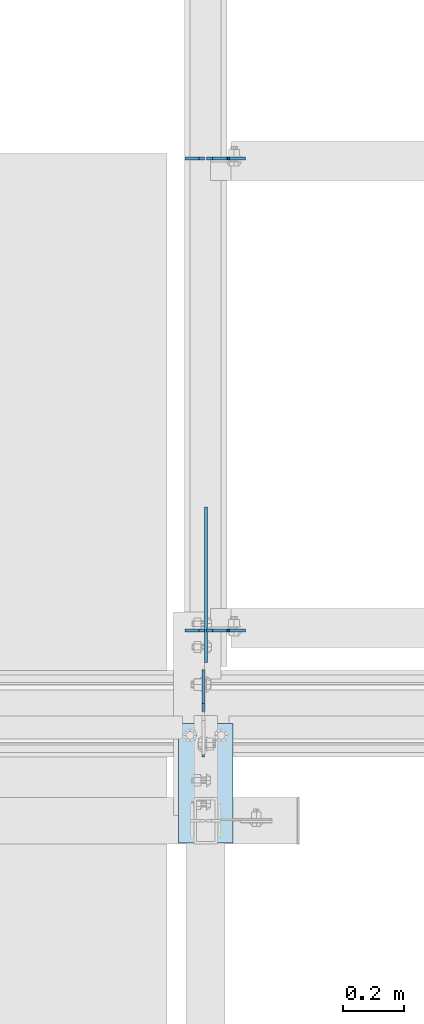
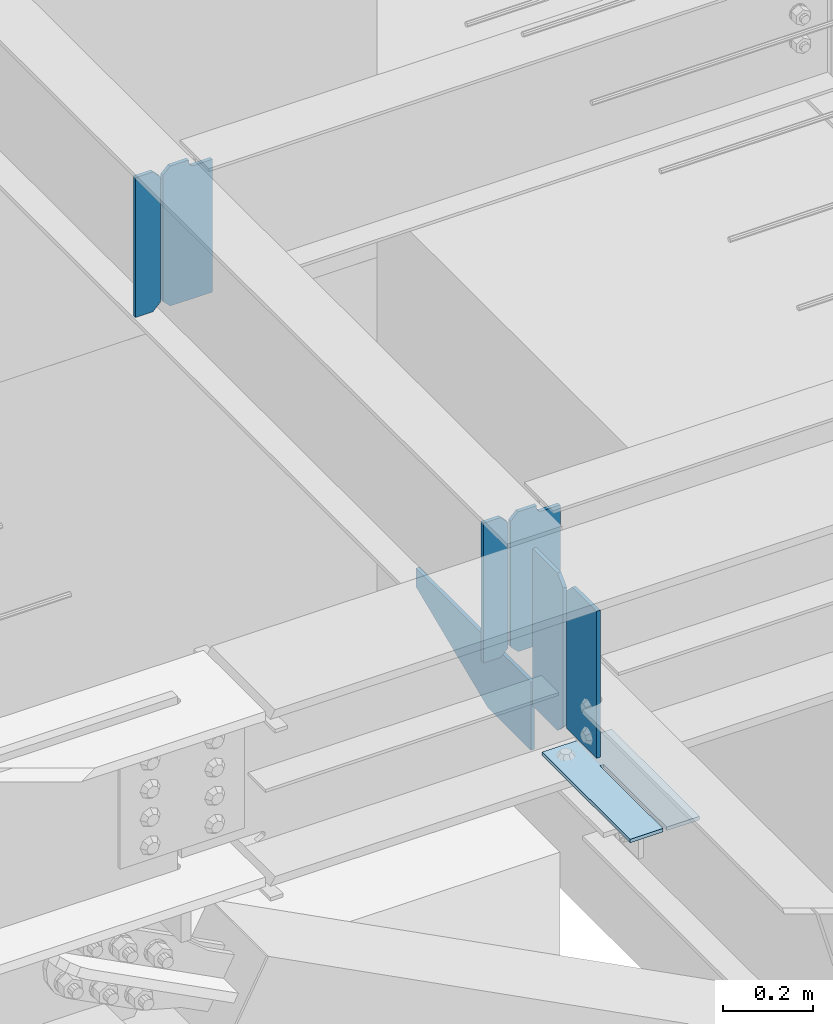
# One storey, part 999 of 1179: 8 plates, 3 elements without a shape of their own.
"""IFC2X3 building model written with IfcOpenShell, lengths in millimetres."""

from ifc_helpers import new_model, si_unit, frame, origin_with_axes, place, context, subcontext, project, spatial, faceted_brep, material, type_object, element, aggregate, save


model = new_model("IFC2X3")

# Units and contexts
model_context = context("Model", 3, precision=1e-05, world=origin_with_axes())
body_context = subcontext(model_context, "Body", "Model", "MODEL_VIEW")
ifc_project = project(units=[si_unit("LENGTHUNIT", "METRE", prefix="MILLI"), si_unit("AREAUNIT", "SQUARE_METRE"), si_unit("VOLUMEUNIT", "CUBIC_METRE"), si_unit("MASSUNIT", "GRAM", prefix="KILO"), si_unit("TIMEUNIT", "SECOND"), si_unit("PLANEANGLEUNIT", "RADIAN"), si_unit("SOLIDANGLEUNIT", "STERADIAN"), si_unit("THERMODYNAMICTEMPERATUREUNIT", "DEGREE_CELSIUS"), si_unit("LUMINOUSINTENSITYUNIT", "LUMEN")], contexts=[model_context])

# Site, building, storey
site_placement = place(None, origin_with_axes())
site = spatial("IfcSite", under=ifc_project, at=site_placement, CompositionType="ELEMENT")
building_placement = place(site_placement, origin_with_axes())
building = spatial("IfcBuilding", under=site, at=building_placement, Name="Undefined", CompositionType="ELEMENT")
storey_placement = place(building_placement, origin_with_axes())
storey = spatial("IfcBuildingStorey", under=building, at=storey_placement, Name="Undefined", CompositionType="ELEMENT", Elevation=0.0)

# Assembly, plates
assembly_1_placement = place(storey_placement, origin_with_axes())
assembly_1 = element("IfcElementAssembly", 1, at=assembly_1_placement, inside=storey, Name="BEAM", AssemblyPlace="NOTDEFINED", PredefinedType="RIGID_FRAME")
ifc_material = material(Name="STEEL/A36")
plate_type_1 = type_object("IfcPlateType", PredefinedType="NOTDEFINED")
plate_1_placement = place(assembly_1_placement, frame((18418.175, 5707.06200008392, 3711.575), z_axis=(0.0, 0.0, 1.0), x_axis=(1.0, 0.0, 0.0)))
plate_1 = element("IfcPlate", 2, at=plate_1_placement, type_object=plate_type_1, material=ifc_material, Name="PLATE", context=body_context, shape_type="Brep", body=[
    faceted_brep([(66.6743865212811, -4.76249999999709, 377.825), (66.6745864763507, -4.76249999999709, 371.474599924168), (66.6745876193563, 4.76249999999709, 371.474599924203), (66.6743876643031, 4.76249999999709, 377.825), (67.6414311678836, -4.76249999999709, 366.614643208318), (67.6414323108893, 4.76249999999709, 366.614643208353), (70.3944716748138, -4.76249999999709, 362.494602443389), (70.3944728178176, 4.76249999999709, 362.494602443423), (74.5145991226364, -4.76249999999709, 359.741691665477), (74.514600265642, 4.76249999999709, 359.741691665511), (79.3745862790947, -4.76249999999709, 358.774999999796), (79.3745874221004, 4.76249999999709, 358.774999999831), (127.000000004868, -4.76249999999709, 358.774999992755), (127.0, 4.76249999999709, 358.774999992755), (0.0, -4.76249999999709, 358.775000762939), (19.0499992370605, -4.76249999999709, 377.825), (19.0499992370605, 4.76249999999709, 377.825), (0.0, 4.76249999999709, 358.775000762939), (0.0, -4.76250000000073, 19.0499992370605), (0.0, 4.76250000000073, 19.0499992370605), (19.0499992370605, -4.76250000000073, 0.0), (19.0499992370605, 4.76250000000073, 0.0), (127.0, -4.76250000000073, 0.0), (127.0, 4.76250000000073, 0.0)], [[[0, 1, 2, 3]], [[4, 5, 2, 1]], [[6, 7, 5, 4]], [[8, 9, 7, 6]], [[10, 11, 9, 8]], [[12, 13, 11, 10]], [[14, 15, 16, 17]], [[18, 14, 17, 19]], [[20, 18, 19, 21]], [[22, 20, 21, 23]], [[8, 6, 4, 1, 0, 15, 14, 18, 20, 22, 12, 10]], [[16, 15, 0, 3]], [[23, 21, 19, 17, 16, 3, 2, 5, 7, 9, 11, 13]], [[22, 23, 13, 12]]]),
])
plate_2_placement = place(assembly_1_placement, frame((18418.175, 7246.93799991608, 3711.575), z_axis=(0.0, 0.0, 1.0), x_axis=(1.0, 0.0, 0.0)))
plate_2 = element("IfcPlate", 3, at=plate_2_placement, type_object=plate_type_1, material=ifc_material, Name="PLATE", context=body_context, shape_type="Brep", body=[
    faceted_brep([(66.6743865212811, -4.76249999999709, 377.825), (66.6745864763507, -4.76249999999709, 371.474599924168), (66.6745876193563, 4.76249999999709, 371.474599924203), (66.6743876643031, 4.76249999999709, 377.825), (67.6414311678836, -4.76249999999709, 366.614643208318), (67.6414323108893, 4.76249999999709, 366.614643208353), (70.3944716748138, -4.76249999999709, 362.494602443389), (70.3944728178176, 4.76249999999709, 362.494602443423), (74.5145991226364, -4.76249999999709, 359.741691665477), (74.514600265642, 4.76249999999709, 359.741691665511), (79.3745862790947, -4.76249999999709, 358.774999999796), (79.3745874221004, 4.76249999999709, 358.774999999831), (127.000000004868, -4.76249999999709, 358.774999992755), (127.0, 4.76249999999709, 358.774999992755), (0.0, -4.76249999999709, 358.775000762939), (19.0499992370605, -4.76249999999709, 377.825), (19.0499992370605, 4.76249999999709, 377.825), (0.0, 4.76249999999709, 358.775000762939), (0.0, -4.76250000000073, 19.0499992370605), (0.0, 4.76250000000073, 19.0499992370605), (19.0499992370605, -4.76250000000073, 0.0), (19.0499992370605, 4.76250000000073, 0.0), (127.0, -4.76250000000073, 0.0), (127.0, 4.76250000000073, 0.0)], [[[0, 1, 2, 3]], [[4, 5, 2, 1]], [[6, 7, 5, 4]], [[8, 9, 7, 6]], [[10, 11, 9, 8]], [[12, 13, 11, 10]], [[14, 15, 16, 17]], [[18, 14, 17, 19]], [[20, 18, 19, 21]], [[22, 20, 21, 23]], [[8, 6, 4, 1, 0, 15, 14, 18, 20, 22, 12, 10]], [[16, 15, 0, 3]], [[23, 21, 19, 17, 16, 3, 2, 5, 7, 9, 11, 13]], [[22, 23, 13, 12]]]),
])

assembly_2_placement = place(storey_placement, origin_with_axes())
assembly_2 = element("IfcElementAssembly", 4, at=assembly_2_placement, inside=storey, Name="BEAM", AssemblyPlace="NOTDEFINED", PredefinedType="RIGID_FRAME")
plate_type_2 = type_object("IfcPlateType", PredefinedType="NOTDEFINED")
plate_3_placement = place(assembly_2_placement, frame((18407.0624967425, 5294.3125001143, 3683.00001220703), z_axis=(0.0, 0.0, 1.0), x_axis=(0.0, 1.0, 0.0)))
plate_3 = element("IfcPlate", 5, at=plate_3_placement, type_object=plate_type_2, material=ifc_material, Name="PLATE", context=body_context, shape_type="Brep", body=[
    faceted_brep([(0.0, -4.76249999999709, 0.0), (1.81898940354586e-12, -4.76250000000437, 396.875), (0.0, 4.762500000008, 396.875), (0.0, 4.76249999999709, 0.0), (108.74389076233, -4.76249999996799, 396.875), (108.743890762327, 4.76250000003165, 396.875), (134.14389038086, -4.76249999996253, 371.47500038147), (134.143890380858, 4.76250000003711, 371.47500038147), (134.14389038086, -4.76249999996253, 0.0), (134.143890380858, 4.76250000003711, 0.0)], [[[0, 1, 2, 3]], [[1, 4, 5, 2]], [[4, 6, 7, 5]], [[6, 8, 9, 7]], [[8, 0, 3, 9]], [[5, 7, 9, 3, 2]], [[8, 6, 4, 1, 0]]]),
])
plate_4_placement = place(assembly_2_placement, frame((18407.0620000839, 5442.74375, 3652.8375), z_axis=(0.0, 0.0, 1.0), x_axis=(0.0, 1.0, 0.0)))
plate_4 = element("IfcPlate", 6, at=plate_4_placement, type_object=plate_type_2, material=ifc_material, Name="PLATE", context=body_context, shape_type="Brep", body=[
    faceted_brep([(0.0, -4.76250000000073, 25.3999996185303), (9.09494701772928e-13, -4.76250000000073, 400.05000038147), (2.72848410531878e-12, 4.76249999999891, 400.05000038147), (0.0, 4.76250000000073, 25.3999996185303), (25.3999996185312, -4.76250000000709, 425.45), (25.399999618533, 4.76249999999254, 425.45), (134.937500000001, -4.76250000003438, 425.45), (134.937500000003, 4.76249999996526, 425.45), (134.937500000001, -4.76250000003438, 0.0), (134.937500000003, 4.76249999996526, 0.0), (25.3999996185303, -4.76250000000073, 0.0), (25.3999996185303, 4.76250000000073, 0.0)], [[[0, 1, 2, 3]], [[1, 4, 5, 2]], [[4, 6, 7, 5]], [[6, 8, 9, 7]], [[8, 10, 11, 9]], [[10, 0, 3, 11]], [[5, 7, 9, 11, 3, 2]], [[10, 8, 6, 4, 1, 0]]]),
])
aggregate(assembly_2, [plate_3, plate_4])

# Assembly, plate
assembly_3_placement = place(storey_placement, origin_with_axes())
assembly_3 = element("IfcElementAssembly", 7, at=assembly_3_placement, inside=storey, Name="BEAM", AssemblyPlace="NOTDEFINED", PredefinedType="RIGID_FRAME")
plate_type_3 = type_object("IfcPlateType", PredefinedType="NOTDEFINED")
plate_5_placement = place(assembly_3_placement, frame((18503.8999993714, 5403.05638849582, 3656.0125), z_axis=(0.0, -1.0, 0.0), x_axis=(-1.0, 0.0, 0.0)))
plate_5 = element("IfcPlate", 8, at=plate_5_placement, type_object=plate_type_3, material=ifc_material, Name="PLATE", context=body_context, shape_type="Brep", body=[
    faceted_brep([(84.1374995016549, -4.76249999999982, 388.937506103519), (84.1374997809262, -4.76249999999982, 109.537497498053), (84.1374997809262, 4.76249999999982, 109.537497498053), (84.1374995016549, 4.76249999999982, 388.937506103519), (93.6624993994565, -4.76249999999982, 109.537497513039), (93.6624993994565, 4.76249999999982, 109.537497513039), (93.6624981665036, -4.76249999999982, 388.93749748426), (93.6624981665036, 4.76249999999982, 388.937506103519), (0.0, -4.76249999999709, 0.0), (-1.46801176015288e-06, -4.76249999999982, 388.937506103516), (-1.46801176015288e-06, 4.76249999999982, 388.937506103516), (0.0, 4.76249999999709, 0.0), (177.800003051758, -4.76249999999982, 0.0), (177.800003051758, 4.76249999999982, 0.0), (177.799987132177, -4.76249999999982, 388.937506103521), (177.799987132177, 4.76249999999982, 388.937506103521)], [[[0, 1, 2, 3]], [[4, 5, 2, 1]], [[6, 7, 5, 4]], [[8, 9, 10, 11]], [[12, 8, 11, 13]], [[14, 12, 13, 15]], [[1, 0, 9, 8, 12, 14, 6, 4]], [[10, 9, 0, 3]], [[15, 13, 11, 10, 3, 2, 5, 7]], [[14, 15, 7, 6]]]),
])
aggregate(assembly_3, [plate_5])

# Plate
plate_type_4 = type_object("IfcPlateType", PredefinedType="NOTDEFINED")
plate_6_placement = place(assembly_1_placement, frame((18411.825, 5707.06200008392, 3711.575), z_axis=(0.0, 0.0, 1.0), x_axis=(-1.0, 0.0, 0.0)))
plate_6 = element("IfcPlate", 9, at=plate_6_placement, type_object=plate_type_4, material=ifc_material, Name="PLATE", context=body_context, shape_type="Brep", body=[
    faceted_brep([(0.0, -4.76250000000073, 19.0499992370605), (0.0, -4.76249999999709, 358.775000762939), (0.0, 4.76249999999709, 358.775000762939), (0.0, 4.76250000000073, 19.0499992370605), (19.0499992370605, -4.76249999999709, 377.825), (19.0499992370605, 4.76249999999709, 377.825), (63.5, -4.76250000000073, 377.825012207031), (63.5, 4.76250000000073, 377.825012207031), (63.5, -4.76250000000073, 0.0), (63.5, 4.76250000000073, 0.0), (19.0499992370605, -4.76250000000073, 0.0), (19.0499992370605, 4.76250000000073, 0.0)], [[[0, 1, 2, 3]], [[1, 4, 5, 2]], [[4, 6, 7, 5]], [[6, 8, 9, 7]], [[8, 10, 11, 9]], [[10, 0, 3, 11]], [[5, 7, 9, 11, 3, 2]], [[10, 8, 6, 4, 1, 0]]]),
])

plate_7_placement = place(assembly_1_placement, frame((18411.825, 7246.93799991608, 3711.575), z_axis=(0.0, 0.0, 1.0), x_axis=(-1.0, 0.0, 0.0)))
plate_7 = element("IfcPlate", 10, at=plate_7_placement, type_object=plate_type_4, material=ifc_material, Name="PLATE", context=body_context, shape_type="Brep", body=[
    faceted_brep([(0.0, -4.76250000000073, 19.0499992370605), (0.0, -4.76249999999709, 358.775000762939), (0.0, 4.76249999999709, 358.775000762939), (0.0, 4.76250000000073, 19.0499992370605), (19.0499992370605, -4.76249999999709, 377.825), (19.0499992370605, 4.76249999999709, 377.825), (63.5, -4.76250000000073, 377.825012207031), (63.5, 4.76250000000073, 377.825012207031), (63.5, -4.76250000000073, 0.0), (63.5, 4.76250000000073, 0.0), (19.0499992370605, -4.76250000000073, 0.0), (19.0499992370605, 4.76250000000073, 0.0)], [[[0, 1, 2, 3]], [[1, 4, 5, 2]], [[4, 6, 7, 5]], [[6, 8, 9, 7]], [[8, 10, 11, 9]], [[10, 0, 3, 11]], [[5, 7, 9, 11, 3, 2]], [[10, 8, 6, 4, 1, 0]]]),
])

plate_type_5 = type_object("IfcPlateType", PredefinedType="NOTDEFINED")
plate_8_placement = place(assembly_1_placement, frame((18416.587511866, 5602.2874999619, 3698.875), z_axis=(0.0, 1.0, 0.0), x_axis=(0.0, 0.0, -1.0)))
plate_8 = element("IfcPlate", 11, at=plate_8_placement, type_object=plate_type_5, material=ifc_material, Name="PLATE", context=body_context, shape_type="Brep", body=[
    faceted_brep([(0.0, -4.76249999999709, 0.0), (0.0, -4.76249999999982, 508.0), (0.0, 4.76249999999982, 508.0), (0.0, 4.76249999999709, 0.0), (50.7999992370605, -4.76249999999982, 508.0), (50.7999992370605, 4.76249999999982, 508.0), (184.150009155273, -4.76249999995343, 190.500000000003), (184.150009155273, 4.76250000004438, 190.500000000001), (184.150009155273, -4.76250000000437, 2.72848410531878e-12), (184.150009155273, 4.76249999999709, 9.09494701772928e-13)], [[[0, 1, 2, 3]], [[1, 4, 5, 2]], [[4, 6, 7, 5]], [[6, 8, 9, 7]], [[8, 0, 3, 9]], [[5, 7, 9, 3, 2]], [[8, 6, 4, 1, 0]]]),
])

aggregate(assembly_1, [plate_6, plate_1, plate_7, plate_2, plate_8])

save(model, "model.ifc")
